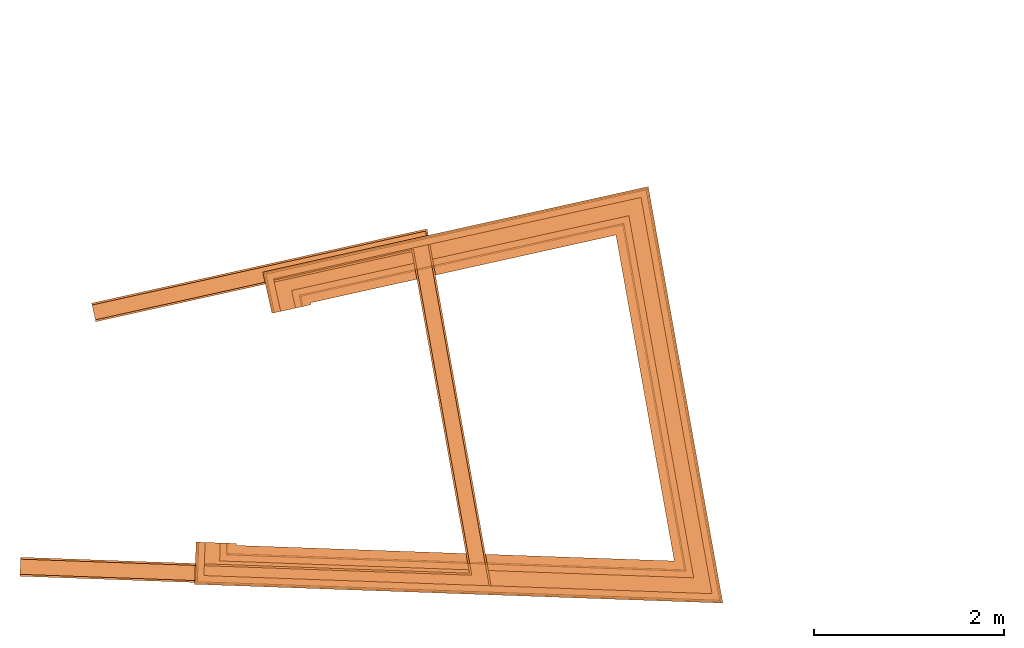
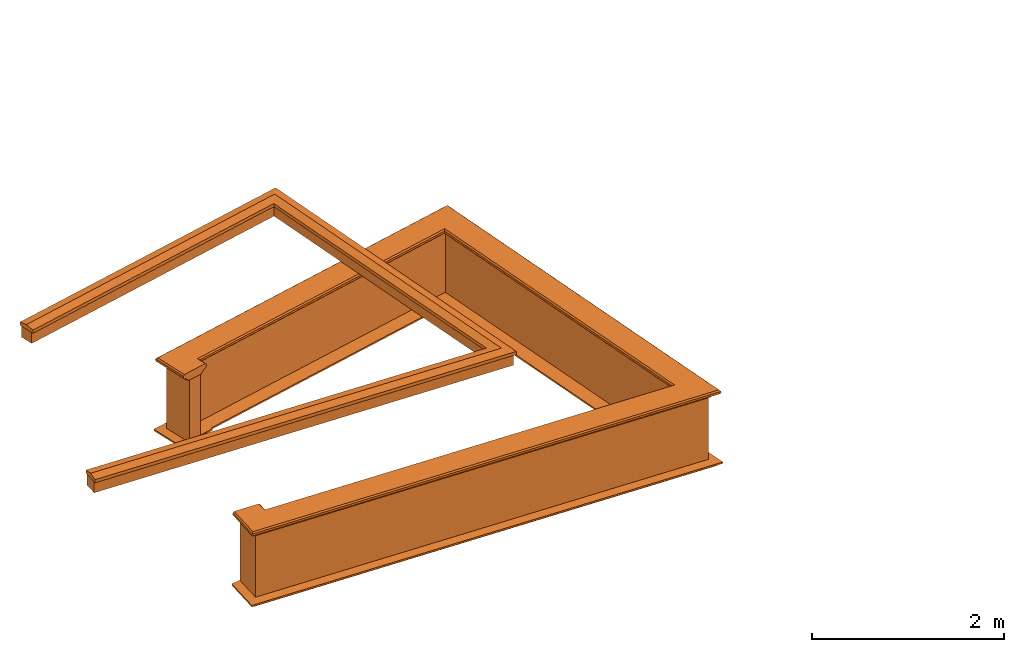
# One storey, part 10 of 11: 5 proxies.
"""IFC2X3 building model written with IfcOpenShell, lengths in metres."""

from ifc_helpers import new_model, entity, si_unit, frame, origin, place, context, subcontext, project, spatial, element, save


model = new_model("IFC2X3")

# Units and contexts
model_context = context("Model", 3, world=origin())
body_context = subcontext(model_context, "Body", "Model", "MODEL_VIEW")
ifc_project = project(units=[si_unit("PLANEANGLEUNIT", "RADIAN"), si_unit("MASSUNIT", "GRAM", prefix="KILO"), si_unit("FORCEUNIT", "NEWTON", prefix="KILO"), si_unit("LENGTHUNIT", "METRE")], contexts=[model_context])

# Site, building, storey
site_placement = place(None, origin())
site = spatial("IfcSite", under=ifc_project, at=site_placement, CompositionType="ELEMENT")
building_placement = place(None, origin())
building = spatial("IfcBuilding", under=site, at=building_placement, Name="Building plot-16", CompositionType="ELEMENT")
storey_placement = place(None, frame((0.0, 0.0, 9.0)))
storey = spatial("IfcBuildingStorey", under=building, at=storey_placement, Name="Floor 2", CompositionType="ELEMENT", Elevation=9.0)

# Proxies
proxy_1_placement = place(storey_placement, origin())
axis2_placement3_d_1 = entity("IfcAxis2Placement3D", entity("IfcCartesianPoint", [0.0, 0.0, 0.0]))
element("IfcBuildingElementProxy", 1, at=proxy_1_placement, inside=storey, Name="parapet", CompositionType="ELEMENT", context=body_context, shape_type="SweptSolid", held_by="IfcProductRepresentation", body=[
    entity("IfcSurfaceCurveSweptAreaSolid", entity("IfcArbitraryClosedProfileDef", "AREA", None, entity("IfcPolyline", [entity("IfcCartesianPoint", [0.0, 0.25]), entity("IfcCartesianPoint", [0.795, 0.25]), entity("IfcCartesianPoint", [0.795, 0.09]), entity("IfcCartesianPoint", [0.02, 0.09]), entity("IfcCartesianPoint", [0.02, -0.08]), entity("IfcCartesianPoint", [0.0, -0.08]), entity("IfcCartesianPoint", [0.0, 0.25])])), axis2_placement3_d_1, entity("IfcPolyline", [entity("IfcCartesianPoint", [97.0209539915277, 33.2168627183288]), entity("IfcCartesianPoint", [97.017398445054, 33.1169259478723]), entity("IfcCartesianPoint", [101.80979404861, 32.9464222862981]), entity("IfcCartesianPoint", [101.162607181796, 36.5590282728232]), entity("IfcCartesianPoint", [97.7895041361907, 35.8110018708005]), entity("IfcCartesianPoint", [97.8111543725478, 35.7133736614259])]), 0.0, 1.0, entity("IfcPlane", axis2_placement3_d_1)),
])
proxy_2_placement = place(storey_placement, origin())
axis2_placement3_d_2 = entity("IfcAxis2Placement3D", entity("IfcCartesianPoint", [0.0, 0.0, 0.0]))
element("IfcBuildingElementProxy", 2, at=proxy_2_placement, inside=storey, Name="parapet", CompositionType="ELEMENT", context=body_context, shape_type="SweptSolid", held_by="IfcProductRepresentation", body=[
    entity("IfcSurfaceCurveSweptAreaSolid", entity("IfcArbitraryClosedProfileDef", "AREA", None, entity("IfcPolyline", [entity("IfcCartesianPoint", [0.795, 0.265]), entity("IfcCartesianPoint", [0.807, 0.268]), entity("IfcCartesianPoint", [0.816, 0.274]), entity("IfcCartesianPoint", [0.822, 0.283]), entity("IfcCartesianPoint", [0.825, 0.295]), entity("IfcCartesianPoint", [0.84, 0.295]), entity("IfcCartesianPoint", [0.84, 0.305]), entity("IfcCartesianPoint", [0.842, 0.317]), entity("IfcCartesianPoint", [0.849, 0.326]), entity("IfcCartesianPoint", [0.858, 0.333]), entity("IfcCartesianPoint", [0.87, 0.335]), entity("IfcCartesianPoint", [0.882, 0.333]), entity("IfcCartesianPoint", [0.891, 0.326]), entity("IfcCartesianPoint", [0.898, 0.317]), entity("IfcCartesianPoint", [0.9, 0.305]), entity("IfcCartesianPoint", [0.9, 0.035]), entity("IfcCartesianPoint", [0.898, 0.023]), entity("IfcCartesianPoint", [0.891, 0.014]), entity("IfcCartesianPoint", [0.882, 0.007]), entity("IfcCartesianPoint", [0.87, 0.005]), entity("IfcCartesianPoint", [0.858, 0.007]), entity("IfcCartesianPoint", [0.849, 0.014]), entity("IfcCartesianPoint", [0.842, 0.023]), entity("IfcCartesianPoint", [0.84, 0.035]), entity("IfcCartesianPoint", [0.84, 0.045]), entity("IfcCartesianPoint", [0.825, 0.045]), entity("IfcCartesianPoint", [0.822, 0.057]), entity("IfcCartesianPoint", [0.816, 0.066]), entity("IfcCartesianPoint", [0.807, 0.072]), entity("IfcCartesianPoint", [0.795, 0.075]), entity("IfcCartesianPoint", [0.795, 0.265])])), axis2_placement3_d_2, entity("IfcPolyline", [entity("IfcCartesianPoint", [97.0209539915277, 33.2168627183288]), entity("IfcCartesianPoint", [97.017398445054, 33.1169259478723]), entity("IfcCartesianPoint", [101.80979404861, 32.9464222862981]), entity("IfcCartesianPoint", [101.162607181796, 36.5590282728232]), entity("IfcCartesianPoint", [97.7895041361907, 35.8110018708005]), entity("IfcCartesianPoint", [97.8111543725478, 35.7133736614259])]), 0.0, 1.0, entity("IfcPlane", axis2_placement3_d_2)),
])
proxy_3_placement = place(storey_placement, origin())
axis2_placement3_d_3 = entity("IfcAxis2Placement3D", entity("IfcCartesianPoint", [0.0, 0.0, 0.0]))
element("IfcBuildingElementProxy", 3, at=proxy_3_placement, inside=storey, Name="parapet", CompositionType="ELEMENT", context=body_context, shape_type="SweptSolid", held_by="IfcProductRepresentation", body=[
    entity("IfcSurfaceCurveSweptAreaSolid", entity("IfcArbitraryClosedProfileDef", "AREA", None, entity("IfcPolyline", [entity("IfcCartesianPoint", [-0.1, 0.25]), entity("IfcCartesianPoint", [-0.1, 0.265]), entity("IfcCartesianPoint", [-0.085, 0.265]), entity("IfcCartesianPoint", [-0.084, 0.278]), entity("IfcCartesianPoint", [-0.081, 0.289]), entity("IfcCartesianPoint", [-0.074, 0.301]), entity("IfcCartesianPoint", [-0.065, 0.309]), entity("IfcCartesianPoint", [-0.055, 0.315]), entity("IfcCartesianPoint", [-0.044, 0.324]), entity("IfcCartesianPoint", [-0.038, 0.334]), entity("IfcCartesianPoint", [-0.035, 0.345]), entity("IfcCartesianPoint", [-0.015, 0.345]), entity("IfcCartesianPoint", [0.0, 0.25]), entity("IfcCartesianPoint", [-0.1, 0.25])])), axis2_placement3_d_3, entity("IfcPolyline", [entity("IfcCartesianPoint", [97.0209539915277, 33.2168627183288]), entity("IfcCartesianPoint", [97.017398445054, 33.1169259478723]), entity("IfcCartesianPoint", [101.80979404861, 32.9464222862981]), entity("IfcCartesianPoint", [101.162607181796, 36.5590282728232]), entity("IfcCartesianPoint", [97.7895041361907, 35.8110018708005]), entity("IfcCartesianPoint", [97.8111543725478, 35.7133736614259])]), 0.0, 1.0, entity("IfcPlane", axis2_placement3_d_3)),
])
proxy_4_placement = place(storey_placement, frame((0.0, 0.0, 2.7)))
axis2_placement3_d_4 = entity("IfcAxis2Placement3D", entity("IfcCartesianPoint", [0.0, 0.0, 0.0]))
element("IfcBuildingElementProxy", 4, at=proxy_4_placement, inside=storey, Name="pergola beam", CompositionType="ELEMENT", context=body_context, shape_type="SweptSolid", held_by="IfcProductRepresentation", body=[
    entity("IfcSurfaceCurveSweptAreaSolid", entity("IfcArbitraryClosedProfileDef", "AREA", None, entity("IfcPolyline", [entity("IfcCartesianPoint", [-0.7, -0.08]), entity("IfcCartesianPoint", [-0.7, 0.08]), entity("IfcCartesianPoint", [-0.56, 0.08]), entity("IfcCartesianPoint", [-0.56, -0.08]), entity("IfcCartesianPoint", [-0.7, -0.08])])), axis2_placement3_d_4, entity("IfcPolyline", [entity("IfcCartesianPoint", [96.9574363827801, 33.1190592757565]), entity("IfcCartesianPoint", [101.80979404861, 32.9464222862981]), entity("IfcCartesianPoint", [101.162607181796, 36.5590282728232]), entity("IfcCartesianPoint", [97.730927210566, 35.7980117289862])]), 0.0, 1.0, entity("IfcPlane", axis2_placement3_d_4)),
])
proxy_5_placement = place(storey_placement, frame((0.0, 0.0, 2.7)))
axis2_placement3_d_5 = entity("IfcAxis2Placement3D", entity("IfcCartesianPoint", [0.0, 0.0, 0.0]))
element("IfcBuildingElementProxy", 5, at=proxy_5_placement, inside=storey, Name="pergola beam", CompositionType="ELEMENT", context=body_context, shape_type="SweptSolid", held_by="IfcProductRepresentation", body=[
    entity("IfcSurfaceCurveSweptAreaSolid", entity("IfcArbitraryClosedProfileDef", "AREA", None, entity("IfcPolyline", [entity("IfcCartesianPoint", [-0.5, 0.0]), entity("IfcCartesianPoint", [-0.52, -0.1]), entity("IfcCartesianPoint", [-0.56, -0.1]), entity("IfcCartesianPoint", [-0.56, 0.1]), entity("IfcCartesianPoint", [-0.52, 0.1]), entity("IfcCartesianPoint", [-0.5, 0.0])])), axis2_placement3_d_5, entity("IfcPolyline", [entity("IfcCartesianPoint", [96.9574363827801, 33.1190592757565]), entity("IfcCartesianPoint", [101.80979404861, 32.9464222862981]), entity("IfcCartesianPoint", [101.162607181796, 36.5590282728232]), entity("IfcCartesianPoint", [97.730927210566, 35.7980117289862])]), 0.0, 1.0, entity("IfcPlane", axis2_placement3_d_5)),
])

save(model, "model.ifc")
